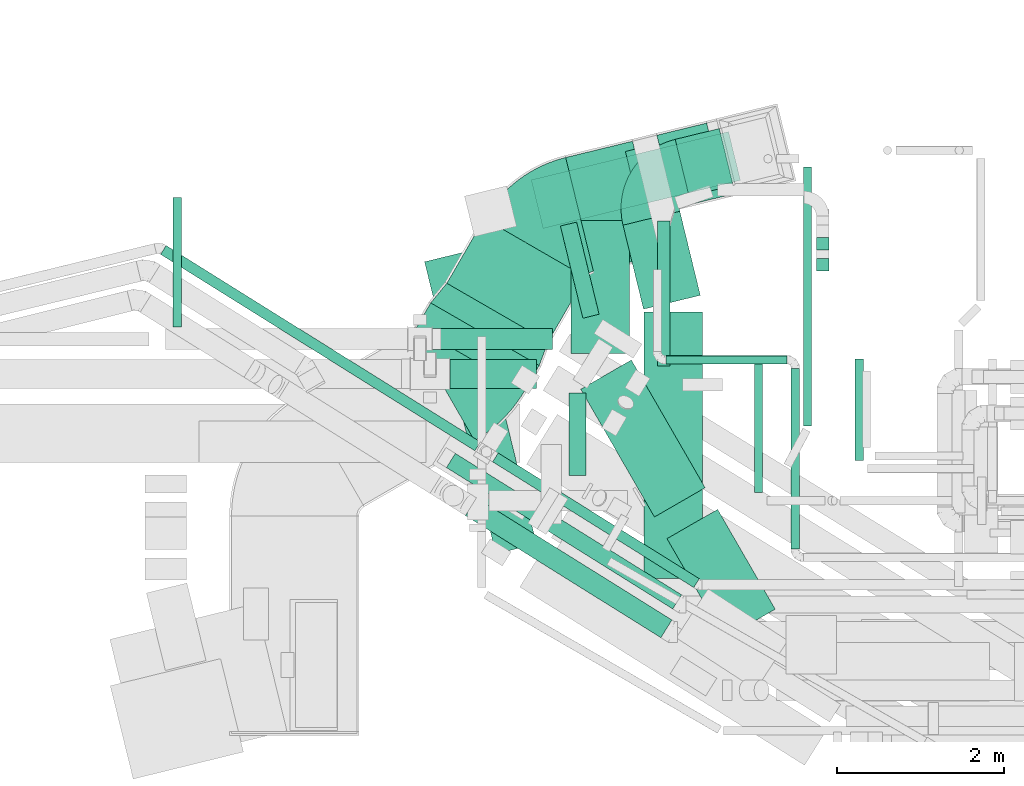
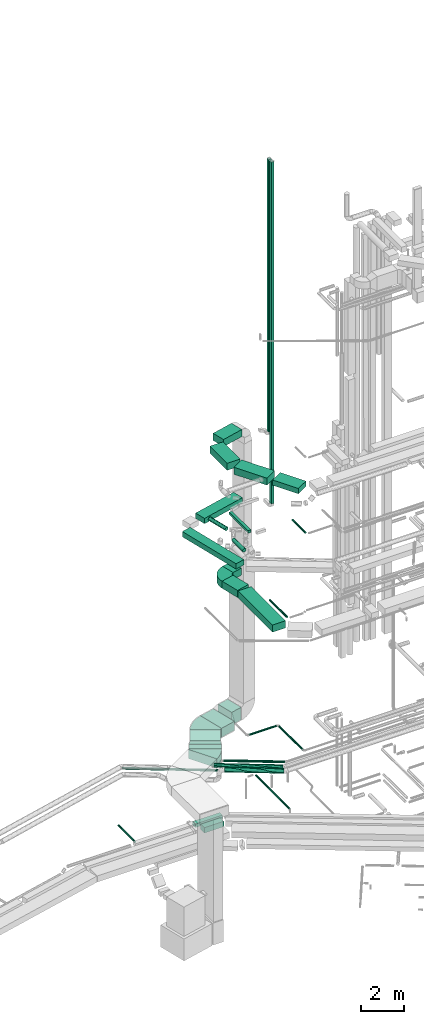
# One storey, part 23 of 337: 30 flow segments, 4 flow fittings.
"""IFC2X3 building model written with IfcOpenShell, lengths in millimetres."""

from ifc_helpers import new_model, entity, si_unit, converted_unit, derived_unit, direction, frame, frame_2d, origin, origin_2d_with_axis, place, context, subcontext, project, spatial, polyline, circle_curve, parameter, trimmed, segment, composite_curve, rectangle, circle, outline, extrude, source, transform, mapped, material, type_object, type_shapes, element, save


model = new_model("IFC2X3")

# Units and contexts
model_context = context("Model", 3, precision=0.01, world=origin(), true_north=direction((6.12303176911189e-17, 1.0)))
body_context = subcontext(model_context, "Body", "Model", "MODEL_VIEW")
ifc_project = project(units=[si_unit("LENGTHUNIT", "METRE", prefix="MILLI"), si_unit("AREAUNIT", "SQUARE_METRE"), si_unit("VOLUMEUNIT", "CUBIC_METRE"), converted_unit("PLANEANGLEUNIT", "DEGREE", entity("IfcRatioMeasure", 0.0174532925199433), si_unit("PLANEANGLEUNIT", "RADIAN"), dimensions=[0, 0, 0, 0, 0, 0, 0]), si_unit("MASSUNIT", "GRAM", prefix="KILO"), derived_unit("MASSDENSITYUNIT", [(si_unit("MASSUNIT", "GRAM", prefix="KILO"), 1), (si_unit("LENGTHUNIT", "METRE"), -3)]), derived_unit("MOMENTOFINERTIAUNIT", [(si_unit("LENGTHUNIT", "METRE"), 4)]), si_unit("TIMEUNIT", "SECOND"), si_unit("FREQUENCYUNIT", "HERTZ"), si_unit("THERMODYNAMICTEMPERATUREUNIT", "DEGREE_CELSIUS"), derived_unit("THERMALTRANSMITTANCEUNIT", [(si_unit("MASSUNIT", "GRAM", prefix="KILO"), 1), (si_unit("THERMODYNAMICTEMPERATUREUNIT", "KELVIN"), -1), (si_unit("TIMEUNIT", "SECOND"), -3)]), derived_unit("VOLUMETRICFLOWRATEUNIT", [(si_unit("LENGTHUNIT", "METRE"), 3), (si_unit("TIMEUNIT", "SECOND"), -1)]), derived_unit("MASSFLOWRATEUNIT", [(si_unit("MASSUNIT", "GRAM", prefix="KILO"), 1), (si_unit("TIMEUNIT", "SECOND"), -1)]), derived_unit("ROTATIONALFREQUENCYUNIT", [(si_unit("TIMEUNIT", "SECOND"), -1)]), si_unit("ELECTRICCURRENTUNIT", "AMPERE"), si_unit("ELECTRICVOLTAGEUNIT", "VOLT"), si_unit("POWERUNIT", "WATT"), si_unit("FORCEUNIT", "NEWTON", prefix="KILO"), si_unit("ILLUMINANCEUNIT", "LUX"), si_unit("LUMINOUSFLUXUNIT", "LUMEN"), si_unit("LUMINOUSINTENSITYUNIT", "CANDELA"), derived_unit("USERDEFINED", [(si_unit("MASSUNIT", "GRAM", prefix="KILO"), -1), (si_unit("LENGTHUNIT", "METRE"), -2), (si_unit("TIMEUNIT", "SECOND"), 3), (si_unit("LUMINOUSFLUXUNIT", "LUMEN"), 1)]), derived_unit("LINEARVELOCITYUNIT", [(si_unit("LENGTHUNIT", "METRE"), 1), (si_unit("TIMEUNIT", "SECOND"), -1)]), si_unit("PRESSUREUNIT", "PASCAL"), derived_unit("USERDEFINED", [(si_unit("LENGTHUNIT", "METRE"), -2), (si_unit("MASSUNIT", "GRAM", prefix="KILO"), 1), (si_unit("TIMEUNIT", "SECOND"), -2)]), derived_unit("LINEARFORCEUNIT", [(si_unit("MASSUNIT", "GRAM", prefix="KILO"), 1), (si_unit("LENGTHUNIT", "METRE"), 1), (si_unit("TIMEUNIT", "SECOND"), -2), (si_unit("LENGTHUNIT", "METRE"), -1)]), derived_unit("PLANARFORCEUNIT", [(si_unit("MASSUNIT", "GRAM", prefix="KILO"), 1), (si_unit("LENGTHUNIT", "METRE"), 1), (si_unit("TIMEUNIT", "SECOND"), -2), (si_unit("LENGTHUNIT", "METRE"), -2)])], contexts=[model_context])

# Site, building, storey
site_placement = place(None, origin())
site = spatial("IfcSite", under=ifc_project, at=site_placement, CompositionType="ELEMENT")
building_placement = place(site_placement, origin())
building = spatial("IfcBuilding", under=site, at=building_placement, CompositionType="ELEMENT")
storey_placement = place(building_placement, origin())
storey = spatial("IfcBuildingStorey", under=building, at=storey_placement, CompositionType="ELEMENT", Elevation=0.0)

# Flow segments
duct_segment_type_1 = type_object("IfcDuctSegmentType", PredefinedType="NOTDEFINED")
flow_segment_1_placement = place(storey_placement, frame((655.1, 15124.67, -650.0)))
element("IfcFlowSegment", 1, at=flow_segment_1_placement, inside=storey, type_object=duct_segment_type_1, context=body_context, shape_type="SweptSolid", body=[
    extrude(rectangle(XDim=1437.07091939898, YDim=249.999999999999, at=origin_2d_with_axis()), frame((718.54, 125.0, 0.0)), (0.0, 0.0, 1.0), 200.0),
])
flow_segment_2_placement = place(storey_placement, frame((560.36, 12679.91, 15150.0)))
element("IfcFlowSegment", 2, at=flow_segment_2_placement, inside=storey, type_object=duct_segment_type_1, context=body_context, shape_type="SweptSolid", body=[
    extrude(rectangle(XDim=3598.50404068253, YDim=499.999999999999, at=origin_2d_with_axis()), frame((668.99, 1807.27, 0.0), z_axis=(0.0, 0.0, 1.0), x_axis=(-0.236819895600926, 0.971553568799769, 0.0)), (0.0, 0.0, 1.0), 300.000000000001),
])
flow_segment_3_placement = place(storey_placement, frame((1835.39, 16573.62, 15150.0)))
element("IfcFlowSegment", 3, at=flow_segment_3_placement, inside=storey, type_object=duct_segment_type_1, context=body_context, shape_type="SweptSolid", body=[
    extrude(rectangle(XDim=2432.90174918883, YDim=600.0, at=origin_2d_with_axis()), frame((1252.9, 580.3, 0.0), z_axis=(0.0, 0.0, 1.0), x_axis=(0.971392173381366, 0.237481042387443, 0.0)), (0.0, 0.0, 1.0), 300.000000000001),
])
flow_segment_4_placement = place(storey_placement, frame((463.0, 14639.1, 3200.0)))
element("IfcFlowSegment", 4, at=flow_segment_4_placement, inside=storey, type_object=duct_segment_type_1, context=body_context, shape_type="SweptSolid", body=[
    extrude(rectangle(XDim=340.281662206534, YDim=1500.0, at=origin_2d_with_axis()), frame((734.59, 522.35, 0.0), z_axis=(0.0, 0.0, 1.0), x_axis=(0.499999999999986, 0.866025403784447, 0.0)), (0.0, 0.0, 1.0), 500.0),
])
flow_segment_5_placement = place(storey_placement, frame((826.44, 15218.6, 3200.0)))
element("IfcFlowSegment", 5, at=flow_segment_5_placement, inside=storey, type_object=duct_segment_type_1, context=body_context, shape_type="SweptSolid", body=[
    extrude(rectangle(XDim=894.67269148178, YDim=1400.0, at=origin_2d_with_axis()), frame((829.89, 737.4, 0.0), z_axis=(0.0, 0.0, 1.0), x_axis=(0.49999999999991, 0.866025403784491, 0.0)), (0.0, 0.0, 1.0), 500.0),
])
flow_segment_6_placement = place(storey_placement, frame((2249.04, 16064.14, 3200.0)))
element("IfcFlowSegment", 6, at=flow_segment_6_placement, inside=storey, type_object=duct_segment_type_1, context=body_context, shape_type="SweptSolid", body=[
    extrude(rectangle(XDim=823.616881377971, YDim=1400.0, at=origin_2d_with_axis()), frame((565.87, 777.61, 0.0), z_axis=(0.0, 0.0, 1.0), x_axis=(0.971552058141478, 0.236826092990315, 0.0)), (0.0, 0.0, 1.0), 500.0),
])
flow_segment_7_placement = place(storey_placement, frame((3340.57, 16816.5, 3100.0)))
element("IfcFlowSegment", 7, at=flow_segment_7_placement, inside=storey, type_object=duct_segment_type_1, context=body_context, shape_type="SweptSolid", body=[
    extrude(rectangle(XDim=614.273800485745, YDim=900.0, at=origin_2d_with_axis()), frame((404.97, 509.94, 0.0), z_axis=(0.0, 0.0, 1.0), x_axis=(0.971552058141473, 0.236826092990338, 0.0)), (0.0, 0.0, 1.0), 700.0),
])
flow_segment_8_placement = place(storey_placement, frame((3185.0, 12386.97, 11150.0)))
element("IfcFlowSegment", 8, at=flow_segment_8_placement, inside=storey, type_object=duct_segment_type_1, context=body_context, shape_type="SweptSolid", body=[
    extrude(rectangle(XDim=3186.20966278234, YDim=700.0, at=origin_2d_with_axis()), frame((350.0, 1593.1, 0.0), z_axis=(0.0, 0.0, 1.0), x_axis=(0.0, 1.0, 0.0)), (0.0, 0.0, 1.0), 400.0),
])
flow_segment_9_placement = place(storey_placement, frame((2935.59, 15608.71, 11150.0)))
element("IfcFlowSegment", 9, at=flow_segment_9_placement, inside=storey, type_object=duct_segment_type_1, context=body_context, shape_type="SweptSolid", body=[
    extrude(rectangle(XDim=1035.09955345977, YDim=700.000000000001, at=origin_2d_with_axis()), frame((462.61, 585.72, 0.0), z_axis=(0.0, 0.0, 1.0), x_axis=(0.236826092990348, -0.971552058141471, 0.0)), (0.0, 0.0, 1.0), 400.0),
])
flow_segment_10_placement = place(storey_placement, frame((2429.11, 13121.13, 18950.0)))
element("IfcFlowSegment", 10, at=flow_segment_10_placement, inside=storey, type_object=duct_segment_type_1, context=body_context, shape_type="SweptSolid", body=[
    extrude(rectangle(XDim=1765.48413790719, YDim=699.999999999999, at=origin_2d_with_axis()), frame((744.48, 939.48, 0.0), z_axis=(0.0, 0.0, 1.0), x_axis=(0.499999999999998, -0.86602540378444, 0.0)), (0.0, 0.0, 1.0), 400.0),
])
flow_segment_11_placement = place(storey_placement, frame((2315.23, 15075.08, 18950.0)))
element("IfcFlowSegment", 11, at=flow_segment_11_placement, inside=storey, type_object=duct_segment_type_1, context=body_context, shape_type="SweptSolid", body=[
    extrude(rectangle(XDim=1595.25442887858, YDim=700.0, at=origin_2d_with_axis()), frame((350.0, 797.63, 0.0), z_axis=(0.0, 0.0, 1.0), x_axis=(0.0, 1.0, 0.0)), (0.0, 0.0, 1.0), 400.0),
])
flow_segment_12_placement = place(storey_placement, frame((2963.93, 16816.07, 18950.0)))
element("IfcFlowSegment", 12, at=flow_segment_12_placement, inside=storey, type_object=duct_segment_type_1, context=body_context, shape_type="SweptSolid", body=[
    extrude(rectangle(XDim=1176.32126692913, YDim=700.000000000001, at=origin_2d_with_axis()), frame((654.32, 479.34, 0.0), z_axis=(0.0, 0.0, 1.0), x_axis=(-0.971552058141475, -0.236826092990329, 0.0)), (0.0, 0.0, 1.0), 400.0),
])
flow_segment_13_placement = place(storey_placement, frame((3461.85, 11667.03, 19050.0)))
element("IfcFlowSegment", 13, at=flow_segment_13_placement, inside=storey, type_object=duct_segment_type_1, context=body_context, shape_type="SweptSolid", body=[
    extrude(rectangle(XDim=1379.05006941641, YDim=700.000000000001, at=origin_2d_with_axis()), frame((647.87, 772.15, 0.0), z_axis=(0.0, 0.0, 1.0), x_axis=(-0.500000000000022, 0.866025403784426, 0.0)), (0.0, 0.0, 1.0), 300.000000000001),
])
flow_segment_14_placement = place(storey_placement, frame((3348.45, 14926.17, 15125.0)))
element("IfcFlowSegment", 14, at=flow_segment_14_placement, inside=storey, type_object=duct_segment_type_1, context=body_context, shape_type="SweptSolid", body=[
    extrude(rectangle(XDim=1740.3336307199, YDim=150.0, at=origin_2d_with_axis()), frame((75.0, 870.17, 0.0), z_axis=(0.0, 0.0, 1.0), x_axis=(0.0, -1.0, 0.0)), (0.0, 0.0, 1.0), 150.000000000001),
])
flow_segment_15_placement = place(storey_placement, frame((866.6, 14658.23, -750.0)))
element("IfcFlowSegment", 15, at=flow_segment_15_placement, inside=storey, type_object=duct_segment_type_1, context=body_context, shape_type="SweptSolid", body=[
    extrude(rectangle(XDim=1032.75527236275, YDim=350.000000000001, at=origin_2d_with_axis()), frame((516.38, 175.0, 0.0), z_axis=(0.0, 0.0, 1.0), x_axis=(-1.0, 0.0, 0.0)), (0.0, 0.0, 1.0), 300.0),
])
flow_segment_16_placement = place(storey_placement, frame((3560.11, 16961.4, 11150.0)))
element("IfcFlowSegment", 16, at=flow_segment_16_placement, inside=storey, type_object=duct_segment_type_1, context=body_context, shape_type="SweptSolid", body=[
    extrude(rectangle(XDim=542.685193539893, YDim=700.0, at=origin_2d_with_axis()), frame((346.51, 404.3, 0.0), z_axis=(0.0, 0.0, 1.0), x_axis=(0.971552058141478, 0.236826092990315, 0.0)), (0.0, 0.0, 1.0), 400.0),
])
flow_segment_17_placement = place(storey_placement, frame((5249.8, 16066.98, 15425.0)))
element("IfcFlowSegment", 17, at=flow_segment_17_placement, inside=storey, type_object=duct_segment_type_1, context=body_context, shape_type="SweptSolid", body=[
    extrude(rectangle(XDim=150.000000000001, YDim=149.999999999999, at=origin_2d_with_axis()), frame((75.0, 75.0, 0.0), z_axis=(0.0, 0.0, 1.0), x_axis=(0.0, 1.0, 0.0)), (0.0, 0.0, 1.0), 19274.9999952435),
])
flow_segment_18_placement = place(storey_placement, frame((5249.8, 16316.98, 19325.0)))
element("IfcFlowSegment", 18, at=flow_segment_18_placement, inside=storey, type_object=duct_segment_type_1, context=body_context, shape_type="SweptSolid", body=[
    extrude(rectangle(XDim=150.000000000001, YDim=149.999999999999, at=origin_2d_with_axis()), frame((75.0, 75.0, 0.0), z_axis=(0.0, 0.0, 1.0), x_axis=(0.0, 1.0, 0.0)), (0.0, 0.0, 1.0), 15375.0),
])
duct_segment_type_2 = type_object("IfcDuctSegmentType", PredefinedType="NOTDEFINED")
flow_segment_19_placement = place(storey_placement, frame((-2451.83, 15394.67, -601.6)))
element("IfcFlowSegment", 19, at=flow_segment_19_placement, inside=storey, type_object=duct_segment_type_2, context=body_context, shape_type="SweptSolid", body=[
    extrude(circle(Radius=50.0, at=origin_2d_with_axis()), frame((51.6, 0.0, 51.6), z_axis=(0.0, 1.0, 0.0), x_axis=(1.0, 0.0, 0.0)), (0.0, 0.0, 1.0), 1551.97470934776),
])
flow_segment_20_placement = place(storey_placement, frame((5092.11, 14209.86, -651.6)))
element("IfcFlowSegment", 20, at=flow_segment_20_placement, inside=storey, type_object=duct_segment_type_2, context=body_context, shape_type="SweptSolid", body=[
    extrude(circle(Radius=50.0, at=origin_2d_with_axis()), frame((51.6, 0.0, 51.6), z_axis=(0.0, 1.0, 0.0), x_axis=(1.0, 0.0, 0.0)), (0.0, 0.0, 1.0), 3098.99916097611),
])
flow_segment_21_placement = place(storey_placement, frame((2184.21, 15498.69, 15198.4)))
element("IfcFlowSegment", 21, at=flow_segment_21_placement, inside=storey, type_object=duct_segment_type_2, context=body_context, shape_type="SweptSolid", body=[
    extrude(circle(Radius=100.0, at=origin_2d_with_axis()), frame((98.75, 1128.85, 101.6), z_axis=(0.236826092990129, -0.971552058141524, 0.0), x_axis=(-0.971552058141524, -0.236826092990129, 0.0)), (0.0, 0.0, 1.0), 1135.88755500101),
])
flow_segment_22_placement = place(storey_placement, frame((-2601.99, 13911.99, 3035.9)))
element("IfcFlowSegment", 22, at=flow_segment_22_placement, inside=storey, type_object=duct_segment_type_2, context=body_context, shape_type="SweptSolid", body=[
    extrude(circle(Radius=62.5, at=origin_2d_with_axis()), frame((3797.24, 54.6, 64.1), z_axis=(-0.84805274377757, 0.529911826412032, 0.0), x_axis=(0.529911826412032, 0.84805274377757, 0.0)), (0.0, 0.0, 1.0), 4436.65990650206),
])
flow_segment_23_placement = place(storey_placement, frame((1372.54, 12274.75, 3585.9)))
element("IfcFlowSegment", 23, at=flow_segment_23_placement, inside=storey, type_object=duct_segment_type_2, context=body_context, shape_type="SweptSolid", body=[
    extrude(circle(Radius=62.5, at=origin_2d_with_axis()), frame((34.71, 1559.35, 64.1), z_axis=(0.848052743777568, -0.529911826412035, 0.0), x_axis=(0.529911826412035, 0.848052743777568, 0.0)), (0.0, 0.0, 1.0), 2839.63318771588),
])
flow_segment_24_placement = place(storey_placement, frame((1047.25, 11674.51, 3473.4)))
element("IfcFlowSegment", 24, at=flow_segment_24_placement, inside=storey, type_object=duct_segment_type_2, context=body_context, shape_type="SweptSolid", body=[
    extrude(circle(Radius=125.0, at=origin_2d_with_axis()), frame((2407.42, 107.6, 126.6), z_axis=(-0.848052743777562, 0.529911826412045, 0.0), x_axis=(-0.529911826412045, -0.848052743777562, 0.0)), (0.0, 0.0, 1.0), 2758.77500444902),
])
flow_segment_25_placement = place(storey_placement, frame((4505.73, 13415.69, 10848.4)))
element("IfcFlowSegment", 25, at=flow_segment_25_placement, inside=storey, type_object=duct_segment_type_2, context=body_context, shape_type="SweptSolid", body=[
    extrude(circle(Radius=50.0, at=origin_2d_with_axis()), frame((51.6, 0.0, 51.6), z_axis=(0.0, 1.0, 0.0), x_axis=(1.0, 0.0, 0.0)), (0.0, 0.0, 1.0), 1600.00000000001),
])
flow_segment_26_placement = place(storey_placement, frame((820.46, 12018.53, 3498.24)))
element("IfcFlowSegment", 26, at=flow_segment_26_placement, inside=storey, type_object=duct_segment_type_2, context=body_context, shape_type="SweptSolid", body=[
    extrude(circle(Radius=100.0, at=origin_2d_with_axis()), frame((54.59, 1778.59, 101.59), z_axis=(0.848052742670373, -0.529911825720209, 5.1099245886975e-05), x_axis=(-0.00287133145226901, -0.00449875220623465, 0.999985758240725)), (0.0, 0.0, 1.0), 3193.3352670687),
])
flow_segment_27_placement = place(storey_placement, frame((4945.6, 12737.83, 3628.4)))
element("IfcFlowSegment", 27, at=flow_segment_27_placement, inside=storey, type_object=duct_segment_type_2, context=body_context, shape_type="SweptSolid", body=[
    extrude(circle(Radius=50.0, at=origin_2d_with_axis()), frame((51.6, 0.0, 51.6), z_axis=(0.0, 1.0, 0.0), x_axis=(1.0, 0.0, 0.0)), (0.0, 0.0, 1.0), 2163.25000000001),
])
flow_segment_28_placement = place(storey_placement, frame((3447.19, 14949.48, 3628.4)))
element("IfcFlowSegment", 28, at=flow_segment_28_placement, inside=storey, type_object=duct_segment_type_2, context=body_context, shape_type="SweptSolid", body=[
    extrude(circle(Radius=50.0, at=origin_2d_with_axis()), frame((0.0, 51.6, 51.6), z_axis=(1.0, 0.0, 0.0), x_axis=(0.0, 1.0, 0.0)), (0.0, 0.0, 1.0), 1449.99999999999),
])
flow_segment_29_placement = place(storey_placement, frame((5711.72, 13800.0, 14948.4)))
element("IfcFlowSegment", 29, at=flow_segment_29_placement, inside=storey, type_object=duct_segment_type_2, context=body_context, shape_type="SweptSolid", body=[
    extrude(circle(Radius=50.0, at=origin_2d_with_axis()), frame((51.6, 0.0, 51.6), z_axis=(0.0, 1.0, 0.0), x_axis=(-1.0, 0.0, 0.0)), (0.0, 0.0, 1.0), 1214.42293512659),
])
flow_segment_30_placement = place(storey_placement, frame((2289.06, 13614.62, 15198.4)))
element("IfcFlowSegment", 30, at=flow_segment_30_placement, inside=storey, type_object=duct_segment_type_2, context=body_context, shape_type="SweptSolid", body=[
    extrude(circle(Radius=100.0, at=origin_2d_with_axis()), frame((101.6, 0.0, 101.6), z_axis=(0.0, 1.0, -3.8473576724374e-06), x_axis=(1.0, 0.0, 0.0)), (0.0, 0.0, 1.0), 993.095983123978),
])

# Flow fittings
ifc_material = material()
duct_fitting_type_1 = type_object("IfcDuctFittingType", PredefinedType="NOTDEFINED", material=ifc_material)
shared_shape_1 = source(origin(), body_context, "Body", "SweptSolid", [
    extrude(outline(polyline([(-271.26, -715.14), (32.88, -715.14), (263.04, 665.82), (-24.66, 764.46), (-271.26, -715.14)])), frame((150.0, 0.0, -250.0), z_axis=(0.0, 0.0, 1.0), x_axis=(0.986393923832144, 0.164398987305356, 0.0)), (0.0, 0.0, 1.0), 500.0),
])
type_shapes(duct_fitting_type_1, [shared_shape_1])
flow_fitting_1_placement = place(storey_placement, frame((1282.66, 15308.79, 3450.0), z_axis=(0.0, 0.0, 1.0), x_axis=(0.499999999999986, 0.866025403784447, 0.0)))
element("IfcFlowFitting", 31, at=flow_fitting_1_placement, inside=storey, type_object=duct_fitting_type_1, material=ifc_material, context=body_context, shape_type="MappedRepresentation", body=[
    mapped(shared_shape_1, transform((0.0, 0.0, 0.0), scale=1.0)),
])
duct_fitting_type_2 = type_object("IfcDuctFittingType", PredefinedType="NOTDEFINED", material=ifc_material)
shared_shape_2 = source(origin(), body_context, "Body", "SweptSolid", [
    extrude(outline(composite_curve([segment(polyline([(-810.29, -225.0), (689.71, -225.0)]), True, "CONTINUOUS"), segment(trimmed(circle_curve(frame_2d((839.71, -225.0), x_axis=(-0.866025403784441, 0.5)), 150.0), [parameter(0.0)], [parameter(30.0000000000003)], True, "PARAMETER"), False, "CONTINUOUS"), segment(polyline([(709.81, -150.0), (-589.23, 600.0)]), True, "CONTINUOUS"), segment(trimmed(circle_curve(frame_2d((839.71, -225.0), x_axis=(-0.866025403784441, 0.5)), 1650.0), [parameter(0.0)], [parameter(30.0000000000003)], True, "PARAMETER"), True, "CONTINUOUS")], self_intersect=False)), frame((-16.15, 60.29, -250.0), z_axis=(0.0, 0.0, 1.0), x_axis=(-0.500000000000005, 0.866025403784436, 0.0)), (0.0, 0.0, 1.0), 500.0),
])
type_shapes(duct_fitting_type_2, [shared_shape_2])
flow_fitting_2_placement = place(storey_placement, frame((991.94, 14805.25, 3450.0), z_axis=(0.0, 0.0, 1.0), x_axis=(0.866025403784441, 0.499999999999995, 0.0)))
element("IfcFlowFitting", 32, at=flow_fitting_2_placement, inside=storey, type_object=duct_fitting_type_2, material=ifc_material, context=body_context, shape_type="MappedRepresentation", body=[
    mapped(shared_shape_2, transform((0.0, 0.0, 0.0), scale=1.0)),
])
duct_fitting_type_3 = type_object("IfcDuctFittingType", PredefinedType="NOTDEFINED", material=ifc_material)
shared_shape_3 = source(origin(), body_context, "Body", "SweptSolid", [
    extrude(outline(composite_curve([segment(polyline([(-831.38, -307.26), (568.62, -307.26)]), True, "CONTINUOUS"), segment(trimmed(circle_curve(frame_2d((718.62, -307.26), x_axis=(-0.690873441879319, 0.722975716954466)), 150.0), [parameter(0.0)], [parameter(46.3007108125472)], True, "PARAMETER"), False, "CONTINUOUS"), segment(polyline([(614.99, -198.82), (-352.23, 813.35)]), True, "CONTINUOUS"), segment(trimmed(circle_curve(frame_2d((718.62, -307.26), x_axis=(-0.690873441879319, 0.722975716954466)), 1550.0), [parameter(0.0)], [parameter(46.3007108125472)], True, "PARAMETER"), True, "CONTINUOUS")], self_intersect=False)), frame((-56.17, 131.38, -250.0), z_axis=(0.0, 0.0, 1.0), x_axis=(-0.722975716954467, 0.690873441879318, 0.0)), (0.0, 0.0, 1.0), 500.0),
])
type_shapes(duct_fitting_type_3, [shared_shape_3])
flow_fitting_3_placement = place(storey_placement, frame((2061.71, 16658.16, 3450.0), z_axis=(0.0, 0.0, 1.0), x_axis=(-0.971552058141474, -0.236826092990334, 0.0)))
element("IfcFlowFitting", 33, at=flow_fitting_3_placement, inside=storey, type_object=duct_fitting_type_3, material=ifc_material, context=body_context, shape_type="MappedRepresentation", body=[
    mapped(shared_shape_3, transform((0.0, 0.0, 0.0), scale=1.0)),
])
duct_fitting_type_4 = type_object("IfcDuctFittingType", PredefinedType="NOTDEFINED", material=ifc_material)
shared_shape_4 = source(origin(), body_context, "Body", "SweptSolid", [
    extrude(outline(composite_curve([segment(polyline([(-600.0, -250.0), (100.0, -250.0)]), True, "CONTINUOUS"), segment(trimmed(circle_curve(frame_2d((250.0, -250.0), x_axis=(0.0, 1.0)), 150.0), [parameter(0.0)], [parameter(90.0000000000016)], True, "PARAMETER"), False, "CONTINUOUS"), segment(polyline([(250.0, -100.0), (250.0, 600.0)]), True, "CONTINUOUS"), segment(trimmed(circle_curve(frame_2d((250.0, -250.0), x_axis=(0.0, 1.0)), 850.0), [parameter(0.0)], [parameter(90.0000000000016)], True, "PARAMETER"), True, "CONTINUOUS")], self_intersect=False)), frame((-250.0, 250.0, -200.0), z_axis=(0.0, 0.0, 1.0), x_axis=(-1.0, 0.0, 0.0)), (0.0, 0.0, 1.0), 400.0),
])
type_shapes(duct_fitting_type_4, [shared_shape_4])
flow_fitting_4_placement = place(storey_placement, frame((3157.22, 17183.03, 11350.0), z_axis=(0.0, 0.0, 1.0), x_axis=(-0.971552058141476, -0.236826092990326, 0.0)))
element("IfcFlowFitting", 34, at=flow_fitting_4_placement, inside=storey, type_object=duct_fitting_type_4, material=ifc_material, context=body_context, shape_type="MappedRepresentation", body=[
    mapped(shared_shape_4, transform((0.0, 0.0, 0.0), scale=1.0)),
])

save(model, "model.ifc")
